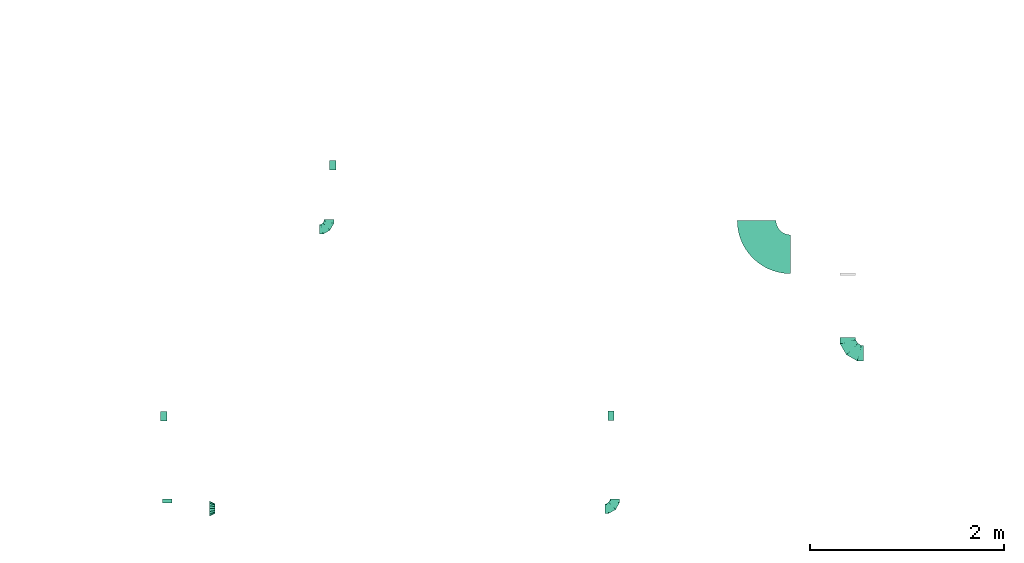
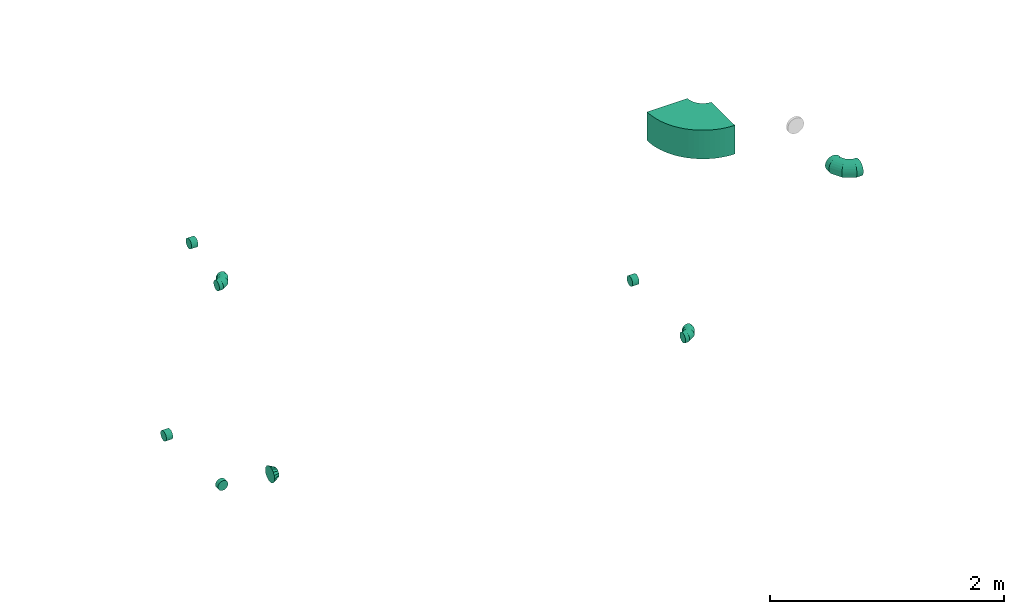
# One storey, part 14 of 32: 9 flow fittings.
"""IFC2X3 building model written with IfcOpenShell, lengths in millimetres."""

import ifcopenshell
import ifcopenshell.guid

model = None  # the IFC model being written
_history = None  # IfcOwnerHistory: only IFC2X3 demands one
_inside = {}  # id of a spatial element -> (the spatial element, [elements in it])
_under = {}  # id of a project, library or spatial element -> (it, [spatial elements below it])
_declared = {}  # id of a project -> (the project, [libraries it declares])
_typed = {}  # id of a type object -> (the type object, [elements of that type])
_made_of = {}  # id of a material, layer set ... -> (it, [elements and type objects made of it])


def new_model(schema):
    """Start an empty IFC model of exactly this schema.

    Asked for "IFC4X3", IfcOpenShell would pick the latest addendum, in which some entities
    have other attributes; the version numbers below select the first issue.
    IFC2X3 requires an IfcOwnerHistory on every rooted entity: one is made here for all.
    """
    global model, _history
    if schema == "IFC4X3":
        model = ifcopenshell.file(schema_version=(4, 3, 0, 0))
    else:
        model = ifcopenshell.file(schema=schema)
    _inside.clear()
    _under.clear()
    _declared.clear()
    _typed.clear()
    _made_of.clear()
    _history = None
    if model.schema == "IFC2X3":
        org = make("IfcOrganization", Name="unknown")
        user = make(
            "IfcPersonAndOrganization",
            ThePerson=make("IfcPerson", FamilyName="unknown"),
            TheOrganization=org,
        )
        app = make(
            "IfcApplication",
            ApplicationDeveloper=org,
            Version="unknown",
            ApplicationFullName="unknown",
            ApplicationIdentifier="unknown",
        )
        _history = make(
            "IfcOwnerHistory",
            OwningUser=user,
            OwningApplication=app,
            ChangeAction="ADDED",
            CreationDate=0,
        )
    return model


def make(cls, **values):
    """One entity of the class cls with the attributes given. An attribute that is None is left unset."""
    return model.create_entity(
        cls, **{name: value for name, value in values.items() if value is not None}
    )


def entity(cls, *values):
    """Any entity or typed value of the class cls, its attributes in the order of the schema. None: left unset."""
    e = model.create_entity(cls)
    for i, value in enumerate(values):
        if value is not None:
            e[i] = value
    return e


def rooted(cls, **values):
    """An entity with a GlobalId (a new one), such as an element, a storey or a relation."""
    return make(cls, GlobalId=ifcopenshell.guid.new(), OwnerHistory=_history, **values)


def si_unit(unit_type, name, prefix=None):
    """IfcSIUnit, for example si_unit("LENGTHUNIT", "METRE", prefix="MILLI")."""
    return make("IfcSIUnit", UnitType=unit_type, Prefix=prefix, Name=name)


def converted_unit(unit_type, name, factor, base, dimensions=None, offset=None):
    """IfcConversionBasedUnit, such as the inch: factor (a typed value) times the base unit."""
    return make(
        "IfcConversionBasedUnit"
        if offset is None
        else "IfcConversionBasedUnitWithOffset",
        ConversionOffset=offset,
        Dimensions=None
        if dimensions is None
        else entity("IfcDimensionalExponents", *dimensions),
        UnitType=unit_type,
        Name=name,
        ConversionFactor=make(
            "IfcMeasureWithUnit", ValueComponent=factor, UnitComponent=base
        ),
    )


def derived_unit(unit_type, elements):
    """IfcDerivedUnit: a product of units, each with its exponent."""
    return make(
        "IfcDerivedUnit",
        Elements=[
            make("IfcDerivedUnitElement", Unit=unit, Exponent=power)
            for unit, power in elements
        ],
        UnitType=unit_type,
    )


def assignment(units):
    """IfcUnitAssignment: the units of a project."""
    return None if units is None else make("IfcUnitAssignment", Units=units)


def point(xyz):
    """IfcCartesianPoint."""
    return None if xyz is None else make("IfcCartesianPoint", Coordinates=xyz)


def direction(xyz):
    """IfcDirection."""
    return None if xyz is None else make("IfcDirection", DirectionRatios=xyz)


def frame(location, z_axis=None, x_axis=None):
    """IfcAxis2Placement3D, a coordinate frame: its origin and axes. An axis left out is left unset."""
    return make(
        "IfcAxis2Placement3D",
        Location=point(location),
        Axis=direction(z_axis),
        RefDirection=direction(x_axis),
    )


def frame_2d(location, x_axis=None):
    """IfcAxis2Placement2D, a coordinate frame in the plane: its origin and x axis."""
    return make(
        "IfcAxis2Placement2D", Location=point(location), RefDirection=direction(x_axis)
    )


def origin():
    """The frame at (0, 0, 0) with its axes left unset."""
    return frame((0.0, 0.0, 0.0))


def place(relative_to, where):
    """IfcLocalPlacement: puts the frame where relative to a parent placement (None: the world)."""
    return make(
        "IfcLocalPlacement", PlacementRelTo=relative_to, RelativePlacement=where
    )


def context(
    kind, dimensions, precision=None, world=None, true_north=None, identifier=None
):
    """IfcGeometricRepresentationContext, for example the 3D "Model" context."""
    return make(
        "IfcGeometricRepresentationContext",
        ContextIdentifier=identifier,
        ContextType=kind,
        CoordinateSpaceDimension=dimensions,
        Precision=precision,
        WorldCoordinateSystem=world,
        TrueNorth=true_north,
    )


def subcontext(parent, identifier, kind, view, scale=None):
    """IfcGeometricRepresentationSubContext, for example "Body" below "Model"."""
    return make(
        "IfcGeometricRepresentationSubContext",
        ContextIdentifier=identifier,
        ContextType=kind,
        ParentContext=parent,
        TargetScale=scale,
        TargetView=view,
    )


def project(units=None, contexts=None):
    """IfcProject with its units and contexts."""
    return rooted(
        "IfcProject",
        Name="project",
        RepresentationContexts=contexts,
        UnitsInContext=assignment(units),
    )


def spatial(cls, under=None, at=None, **own):
    """A site, building, storey or space (cls), placed at a placement, below another one or the project."""
    s = rooted(cls, ObjectPlacement=at, **own)
    if under is not None:
        _under.setdefault(under.id(), (under, []))[1].append(s)
    return s


def polyline(points):
    """IfcPolyline through the points."""
    return make("IfcPolyline", Points=[point(p) for p in points])


def circle_curve(where, radius):
    """IfcCircle in the frame where."""
    return make("IfcCircle", Position=where, Radius=radius)


def parameter(value):
    """IfcParameterValue: where a trimmed curve begins or ends, as a parameter of its basis curve."""
    return model.create_entity("IfcParameterValue", value)


def trimmed(basis, trim1, trim2, sense, master):
    """IfcTrimmedCurve: the piece of a basis curve between two trims."""
    return make(
        "IfcTrimmedCurve",
        BasisCurve=basis,
        Trim1=trim1,
        Trim2=trim2,
        SenseAgreement=sense,
        MasterRepresentation=master,
    )


def segment(curve, same_sense, transition):
    """IfcCompositeCurveSegment."""
    return make(
        "IfcCompositeCurveSegment",
        Transition=transition,
        SameSense=same_sense,
        ParentCurve=curve,
    )


def composite_curve(segments, self_intersect=None):
    """IfcCompositeCurve: segments joined end to end."""
    return make("IfcCompositeCurve", Segments=segments, SelfIntersect=self_intersect)


def outline(outer, holes=None, kind="AREA"):
    """IfcArbitraryClosedProfileDef: a profile drawn as a closed curve; with holes, ...WithVoids."""
    if holes is None:
        return make("IfcArbitraryClosedProfileDef", ProfileType=kind, OuterCurve=outer)
    return make(
        "IfcArbitraryProfileDefWithVoids",
        ProfileType=kind,
        OuterCurve=outer,
        InnerCurves=holes,
    )


def extrude(swept, where, along, depth):
    """IfcExtrudedAreaSolid: the profile swept, set in the frame where, extruded along a direction by depth."""
    return make(
        "IfcExtrudedAreaSolid",
        SweptArea=swept,
        Position=where,
        ExtrudedDirection=direction(along),
        Depth=depth,
    )


def faces_of(points, faces, orient=None, outer=None):
    """IfcFace entities. A face is a list of loops; a loop is a list of indices into points, from 0.

    orient and outer hold one flag for each loop. By default every Orientation is true, the
    first loop of a face is its IfcFaceOuterBound and the others are IfcFaceBound.
    """
    made = []
    for i, loops in enumerate(faces):
        bounds = []
        for j, loop in enumerate(loops):
            is_outer = j == 0 if outer is None else outer[i][j]
            bounds.append(
                make(
                    "IfcFaceOuterBound" if is_outer else "IfcFaceBound",
                    Bound=make("IfcPolyLoop", Polygon=[points[k] for k in loop]),
                    Orientation=True if orient is None else orient[i][j],
                )
            )
        made.append(make("IfcFace", Bounds=bounds))
    return made


def faceted_brep(points, faces, orient=None, outer=None, voids=None):
    """IfcFacetedBrep: a solid bounded by flat faces; with voids (closed shells), ...WithVoids."""
    shared = [point(p) for p in points]
    hull = make("IfcClosedShell", CfsFaces=faces_of(shared, faces, orient, outer))
    if voids is None:
        return make("IfcFacetedBrep", Outer=hull)
    return make(
        "IfcFacetedBrepWithVoids",
        Outer=hull,
        Voids=[
            make(cls, CfsFaces=faces_of(shared, fs, o, b)) for cls, fs, o, b in voids
        ],
    )


def shape(context_of_items, identifier, shape_type, items):
    """IfcShapeRepresentation: the items that make up one representation, for example the "Body"."""
    return make(
        "IfcShapeRepresentation",
        ContextOfItems=context_of_items,
        RepresentationIdentifier=identifier,
        RepresentationType=shape_type,
        Items=items,
    )


def source(mapping_origin, context_of_items, identifier, shape_type, items):
    """IfcRepresentationMap: a shape defined once, which mapped items show again and again."""
    return make(
        "IfcRepresentationMap",
        MappingOrigin=mapping_origin,
        MappedRepresentation=shape(context_of_items, identifier, shape_type, items),
    )


def transform(
    local_origin,
    x_axis=None,
    y_axis=None,
    z_axis=None,
    scale=None,
    scale2=None,
    scale3=None,
    uniform=True,
):
    """IfcCartesianTransformationOperator3D, or its non-uniform kind. x_axis, y_axis, z_axis: its Axis1, 2, 3."""
    if uniform:
        return make(
            "IfcCartesianTransformationOperator3D",
            Axis1=direction(x_axis),
            Axis2=direction(y_axis),
            LocalOrigin=point(local_origin),
            Scale=scale,
            Axis3=direction(z_axis),
        )
    return make(
        "IfcCartesianTransformationOperator3DnonUniform",
        Axis1=direction(x_axis),
        Axis2=direction(y_axis),
        LocalOrigin=point(local_origin),
        Scale=scale,
        Axis3=direction(z_axis),
        Scale2=scale2,
        Scale3=scale3,
    )


def mapped(mapping_source, mapping_target):
    """IfcMappedItem: shows the shape of a source again, moved by a transform."""
    return make(
        "IfcMappedItem", MappingSource=mapping_source, MappingTarget=mapping_target
    )


def material(Name=None, Category=None):
    """IfcMaterial."""
    return make("IfcMaterial", Name=Name, Category=Category)


def made_of(thing, what):
    """Note that an element or type object is made of a material, layer set ...; save() writes the relation."""
    if what is not None:
        _made_of.setdefault(what.id(), (what, []))[1].append(thing)
    return thing


def type_object(cls, material=None, **own):
    """A type object (cls), such as IfcWallType, which elements share."""
    return made_of(rooted(cls, **own), material)


def type_shapes(of_type, sources):
    """Give a type object the sources (RepresentationMaps) that its elements show as mapped items."""
    of_type.RepresentationMaps = sources


def element(
    cls,
    number,
    at=None,
    inside=None,
    cuts=None,
    type_object=None,
    material=None,
    context=None,
    identifier="Body",
    shape_type=None,
    held_by="IfcProductDefinitionShape",
    body=None,
    shapes=None,
    **own,
):
    """One element of the class cls, such as IfcWall. Its Tag is "e" and its number.

    at: its placement. inside: the storey or other place that contains it. cuts: it is an
    opening in that element (IfcRelVoidsElement). A single representation is given by context,
    identifier, shape_type and body (its items); several are given by shapes. held_by: the class
    of the entity that holds the representations. save() writes the other relations.
    """
    e = rooted(cls, Tag="e%d" % number, ObjectPlacement=at, **own)
    if body is not None:
        shapes = [shape(context, identifier, shape_type, body)]
    if shapes is not None:
        e.Representation = make(held_by, Representations=shapes)
    if inside is not None:
        _inside.setdefault(inside.id(), (inside, []))[1].append(e)
    if cuts is not None:
        rooted(
            "IfcRelVoidsElement", RelatingBuildingElement=cuts, RelatedOpeningElement=e
        )
    if type_object is not None:
        _typed.setdefault(type_object.id(), (type_object, []))[1].append(e)
    return made_of(e, material)


def aggregate(whole, parts):
    """IfcRelAggregates: a whole, such as a stair, and the parts it consists of."""
    return rooted("IfcRelAggregates", RelatingObject=whole, RelatedObjects=parts)


def save(model, path):
    """Write the relations noted so far, then the file.

    IfcRelAggregates (storeys below a building ...), IfcRelContainedInSpatialStructure (elements
    in a storey), IfcRelDefinesByType, IfcRelAssociatesMaterial and IfcRelDeclares: one each for
    every whole, place, type object, material and project.
    """
    for whole, parts in _under.values():
        aggregate(whole, parts)
    for where, things in _inside.values():
        rooted(
            "IfcRelContainedInSpatialStructure",
            RelatedElements=things,
            RelatingStructure=where,
        )
    for kind, things in _typed.values():
        rooted("IfcRelDefinesByType", RelatedObjects=things, RelatingType=kind)
    for what, things in _made_of.values():
        rooted("IfcRelAssociatesMaterial", RelatedObjects=things, RelatingMaterial=what)
    for by, libraries in _declared.values():
        rooted("IfcRelDeclares", RelatingContext=by, RelatedDefinitions=libraries)
    model.write(path)


model = new_model("IFC2X3")

# Units and contexts
model_context = context("Model", 3, precision=0.01, world=origin(), true_north=direction((6.12303176911189e-17, 1.0)))
body_context = subcontext(model_context, "Body", "Model", "MODEL_VIEW")
ifc_project = project(units=[si_unit("LENGTHUNIT", "METRE", prefix="MILLI"), si_unit("AREAUNIT", "SQUARE_METRE"), si_unit("VOLUMEUNIT", "CUBIC_METRE"), converted_unit("PLANEANGLEUNIT", "DEGREE", entity("IfcRatioMeasure", 0.0174532925199433), si_unit("PLANEANGLEUNIT", "RADIAN"), dimensions=[0, 0, 0, 0, 0, 0, 0]), si_unit("MASSUNIT", "GRAM", prefix="KILO"), derived_unit("MASSDENSITYUNIT", [(si_unit("MASSUNIT", "GRAM", prefix="KILO"), 1), (si_unit("LENGTHUNIT", "METRE"), -3)]), derived_unit("MOMENTOFINERTIAUNIT", [(si_unit("LENGTHUNIT", "METRE"), 4)]), si_unit("TIMEUNIT", "SECOND"), si_unit("FREQUENCYUNIT", "HERTZ"), si_unit("THERMODYNAMICTEMPERATUREUNIT", "DEGREE_CELSIUS"), derived_unit("THERMALTRANSMITTANCEUNIT", [(si_unit("MASSUNIT", "GRAM", prefix="KILO"), 1), (si_unit("THERMODYNAMICTEMPERATUREUNIT", "KELVIN"), -1), (si_unit("TIMEUNIT", "SECOND"), -3)]), derived_unit("VOLUMETRICFLOWRATEUNIT", [(si_unit("LENGTHUNIT", "METRE"), 3), (si_unit("TIMEUNIT", "SECOND"), -1)]), derived_unit("MASSFLOWRATEUNIT", [(si_unit("MASSUNIT", "GRAM", prefix="KILO"), 1), (si_unit("TIMEUNIT", "SECOND"), -1)]), derived_unit("ROTATIONALFREQUENCYUNIT", [(si_unit("TIMEUNIT", "SECOND"), -1)]), si_unit("ELECTRICCURRENTUNIT", "AMPERE"), si_unit("ELECTRICVOLTAGEUNIT", "VOLT"), si_unit("POWERUNIT", "WATT"), si_unit("FORCEUNIT", "NEWTON", prefix="KILO"), si_unit("ILLUMINANCEUNIT", "LUX"), si_unit("LUMINOUSFLUXUNIT", "LUMEN"), si_unit("LUMINOUSINTENSITYUNIT", "CANDELA"), derived_unit("USERDEFINED", [(si_unit("MASSUNIT", "GRAM", prefix="KILO"), -1), (si_unit("LENGTHUNIT", "METRE"), -2), (si_unit("TIMEUNIT", "SECOND"), 3), (si_unit("LUMINOUSFLUXUNIT", "LUMEN"), 1)]), derived_unit("LINEARVELOCITYUNIT", [(si_unit("LENGTHUNIT", "METRE"), 1), (si_unit("TIMEUNIT", "SECOND"), -1)]), si_unit("PRESSUREUNIT", "PASCAL"), derived_unit("USERDEFINED", [(si_unit("LENGTHUNIT", "METRE"), -2), (si_unit("MASSUNIT", "GRAM", prefix="KILO"), 1), (si_unit("TIMEUNIT", "SECOND"), -2)]), derived_unit("LINEARFORCEUNIT", [(si_unit("MASSUNIT", "GRAM", prefix="KILO"), 1), (si_unit("LENGTHUNIT", "METRE"), 1), (si_unit("TIMEUNIT", "SECOND"), -2), (si_unit("LENGTHUNIT", "METRE"), -1)]), derived_unit("PLANARFORCEUNIT", [(si_unit("MASSUNIT", "GRAM", prefix="KILO"), 1), (si_unit("LENGTHUNIT", "METRE"), 1), (si_unit("TIMEUNIT", "SECOND"), -2), (si_unit("LENGTHUNIT", "METRE"), -2)])], contexts=[model_context])

# Site, building, storey
site_placement = place(None, origin())
site = spatial("IfcSite", under=ifc_project, at=site_placement, CompositionType="ELEMENT")
building_placement = place(site_placement, origin())
building = spatial("IfcBuilding", under=site, at=building_placement, CompositionType="ELEMENT")
storey_placement = place(building_placement, frame((0.0, 0.0, 8100.0)))
storey = spatial("IfcBuildingStorey", under=building, at=storey_placement, CompositionType="ELEMENT", Elevation=8100.0)

# Flow fittings
ifc_material = material()
duct_fitting_type_1 = type_object("IfcDuctFittingType", PredefinedType="NOTDEFINED", material=ifc_material)
shared_shape_1 = source(origin(), body_context, "Body", "Brep", [
    faceted_brep([(-160.0, 0.0, -80.0), (-160.0, -20.71, -77.27), (-160.0, -40.0, -69.28), (-160.0, -56.57, -56.57), (-160.0, -69.28, -40.0), (-160.0, -77.27, -20.71), (-160.0, -80.0, 0.0), (-160.0, -77.27, 20.71), (-160.0, -69.28, 40.0), (-160.0, -56.57, 56.57), (-160.0, -40.0, 69.28), (-160.0, -20.71, 77.27), (-160.0, 0.0, 80.0), (-160.0, 20.71, 77.27), (-160.0, 40.0, 69.28), (-160.0, 56.57, 56.57), (-160.0, 69.28, 40.0), (-160.0, 77.27, 20.71), (-160.0, 80.0, 0.0), (-160.0, 77.27, -20.71), (-160.0, 69.28, -40.0), (-160.0, 56.57, -56.57), (-160.0, 40.0, -69.28), (-160.0, 20.71, -77.27), (-122.68, 20.71, 77.27), (-127.85, 40.0, 69.28), (-117.13, 0.0, 80.0), (-132.29, 56.57, 56.57), (-137.83, 77.27, 20.71), (-138.56, 80.0, 0.0), (-135.69, 69.28, 40.0), (-135.69, 69.28, -40.0), (-132.29, 56.57, -56.57), (-137.83, 77.27, -20.71), (-122.68, 20.71, -77.27), (-117.13, 0.0, -80.0), (-127.85, 40.0, -69.28), (-111.58, -20.71, -77.27), (-106.41, -40.0, -69.28), (-101.97, -56.57, -56.57), (-98.56, -69.28, -40.0), (-96.42, -77.27, -20.71), (-95.69, -80.0, 0.0), (-96.42, -77.27, 20.71), (-98.56, -69.28, 40.0), (-101.97, -56.57, 56.57), (-106.41, -40.0, 69.28), (-111.58, -20.71, 77.27), (-58.03, 58.03, 77.27), (-72.15, 72.15, 69.28), (-42.87, 42.87, 80.0), (-84.28, 84.28, 56.57), (-93.59, 93.59, 40.0), (-99.44, 99.44, 20.71), (-101.44, 101.44, 0.0), (-99.44, 99.44, -20.71), (-93.59, 93.59, -40.0), (-84.28, 84.28, -56.57), (-58.03, 58.03, -77.27), (-42.87, 42.87, -80.0), (-72.15, 72.15, -69.28), (-27.71, 27.71, -77.27), (-13.59, 13.59, -69.28), (-1.46, 1.46, -56.57), (7.85, -7.85, -40.0), (13.7, -13.7, -20.71), (15.69, -15.69, 0.0), (13.7, -13.7, 20.71), (7.85, -7.85, 40.0), (-1.46, 1.46, 56.57), (-13.59, 13.59, 69.28), (-27.71, 27.71, 77.27), (-20.71, 122.68, 77.27), (-40.0, 127.85, 69.28), (0.0, 117.13, 80.0), (-56.57, 132.29, 56.57), (-69.28, 135.69, 40.0), (-77.27, 137.83, 20.71), (-80.0, 138.56, 0.0), (-77.27, 137.83, -20.71), (-69.28, 135.69, -40.0), (-56.57, 132.29, -56.57), (-20.71, 122.68, -77.27), (0.0, 117.13, -80.0), (-40.0, 127.85, -69.28), (20.71, 111.58, -77.27), (40.0, 106.41, -69.28), (56.57, 101.97, -56.57), (69.28, 98.56, -40.0), (77.27, 96.42, -20.71), (80.0, 95.69, 0.0), (77.27, 96.42, 20.71), (69.28, 98.56, 40.0), (56.57, 101.97, 56.57), (40.0, 106.41, 69.28), (20.71, 111.58, 77.27), (-20.71, 160.0, -77.27), (-40.0, 160.0, -69.28), (-56.57, 160.0, -56.57), (-69.28, 160.0, -40.0), (-77.27, 160.0, -20.71), (-80.0, 160.0, 0.0), (-77.27, 160.0, 20.71), (-69.28, 160.0, 40.0), (-56.57, 160.0, 56.57), (-40.0, 160.0, 69.28), (-20.71, 160.0, 77.27), (0.0, 160.0, 80.0), (20.71, 160.0, 77.27), (40.0, 160.0, 69.28), (56.57, 160.0, 56.57), (69.28, 160.0, 40.0), (77.27, 160.0, 20.71), (80.0, 160.0, 0.0), (77.27, 160.0, -20.71), (69.28, 160.0, -40.0), (56.57, 160.0, -56.57), (40.0, 160.0, -69.28), (20.71, 160.0, -77.27), (0.0, 160.0, -80.0)], [[[0, 1, 2, 3, 4, 5, 6, 7, 8, 9, 10, 11, 12, 13, 14, 15, 16, 17, 18, 19, 20, 21, 22, 23]], [[24, 25, 14, 13]], [[26, 24, 13, 12]], [[14, 25, 27, 15]], [[28, 29, 18, 17]], [[30, 28, 17, 16]], [[15, 27, 30, 16]], [[20, 31, 32, 21]], [[33, 31, 20, 19]], [[18, 29, 33, 19]], [[34, 35, 0, 23]], [[36, 34, 23, 22]], [[32, 36, 22, 21]], [[1, 0, 35, 37]], [[2, 1, 37, 38]], [[3, 2, 38, 39]], [[5, 4, 40, 41]], [[6, 5, 41, 42]], [[39, 40, 4, 3]], [[6, 42, 43, 7]], [[7, 43, 44, 8]], [[8, 44, 45, 9]], [[9, 45, 46, 10]], [[10, 46, 47, 11]], [[26, 12, 11, 47]], [[48, 49, 25, 24]], [[50, 48, 24, 26]], [[27, 25, 49, 51]], [[52, 53, 28, 30]], [[51, 52, 30, 27]], [[29, 28, 53, 54]], [[55, 56, 31, 33]], [[54, 55, 33, 29]], [[32, 31, 56, 57]], [[58, 59, 35, 34]], [[60, 58, 34, 36]], [[57, 60, 36, 32]], [[37, 35, 59, 61]], [[38, 37, 61, 62]], [[39, 38, 62, 63]], [[41, 40, 64, 65]], [[42, 41, 65, 66]], [[63, 64, 40, 39]], [[43, 42, 66, 67]], [[44, 43, 67, 68]], [[68, 69, 45, 44]], [[46, 45, 69, 70]], [[47, 46, 70, 71]], [[26, 47, 71, 50]], [[72, 73, 49, 48]], [[74, 72, 48, 50]], [[51, 49, 73, 75]], [[76, 77, 53, 52]], [[75, 76, 52, 51]], [[54, 53, 77, 78]], [[79, 80, 56, 55]], [[78, 79, 55, 54]], [[57, 56, 80, 81]], [[82, 83, 59, 58]], [[84, 82, 58, 60]], [[81, 84, 60, 57]], [[61, 59, 83, 85]], [[62, 61, 85, 86]], [[63, 62, 86, 87]], [[65, 64, 88, 89]], [[66, 65, 89, 90]], [[87, 88, 64, 63]], [[67, 66, 90, 91]], [[68, 67, 91, 92]], [[92, 93, 69, 68]], [[70, 69, 93, 94]], [[71, 70, 94, 95]], [[50, 71, 95, 74]], [[96, 97, 98, 99, 100, 101, 102, 103, 104, 105, 106, 107, 108, 109, 110, 111, 112, 113, 114, 115, 116, 117, 118, 119]], [[72, 74, 107, 106]], [[73, 72, 106, 105]], [[75, 73, 105, 104]], [[77, 76, 103, 102]], [[78, 77, 102, 101]], [[75, 104, 103, 76]], [[78, 101, 100, 79]], [[79, 100, 99, 80]], [[80, 99, 98, 81]], [[84, 97, 96, 82]], [[82, 96, 119, 83]], [[84, 81, 98, 97]], [[118, 117, 86, 85]], [[119, 118, 85, 83]], [[116, 87, 86, 117]], [[88, 115, 114, 89]], [[89, 114, 113, 90]], [[115, 88, 87, 116]], [[112, 111, 92, 91]], [[113, 112, 91, 90]], [[111, 110, 93, 92]], [[95, 94, 109, 108]], [[74, 95, 108, 107]], [[110, 109, 94, 93]]]),
])
type_shapes(duct_fitting_type_1, [shared_shape_1])
flow_fitting_1_placement = place(storey_placement, frame((40938.46, 2102.88, 3250.0), z_axis=(0.0, 0.0, 1.0), x_axis=(0.0, -1.0, 0.0)))
element("IfcFlowFitting", 1, at=flow_fitting_1_placement, inside=storey, type_object=duct_fitting_type_1, material=ifc_material, context=body_context, shape_type="MappedRepresentation", body=[
    mapped(shared_shape_1, transform((0.0, 0.0, 0.0), scale=1.0)),
])
duct_fitting_type_2 = type_object("IfcDuctFittingType", PredefinedType="NOTDEFINED", material=ifc_material)
shared_shape_2 = source(origin(), body_context, "Body", "Brep", [
    faceted_brep([(-100.0, 0.0, -50.0), (-100.0, -12.94, -48.3), (-100.0, -25.0, -43.3), (-100.0, -35.36, -35.36), (-100.0, -43.3, -25.0), (-100.0, -48.3, -12.94), (-100.0, -50.0, 0.0), (-100.0, -48.3, 12.94), (-100.0, -43.3, 25.0), (-100.0, -35.36, 35.36), (-100.0, -25.0, 43.3), (-100.0, -12.94, 48.3), (-100.0, 0.0, 50.0), (-100.0, 12.94, 48.3), (-100.0, 25.0, 43.3), (-100.0, 35.36, 35.36), (-100.0, 43.3, 25.0), (-100.0, 48.3, 12.94), (-100.0, 50.0, 0.0), (-100.0, 48.3, -12.94), (-100.0, 43.3, -25.0), (-100.0, 35.36, -35.36), (-100.0, 25.0, -43.3), (-100.0, 12.94, -48.3), (-76.67, 12.94, 48.3), (-79.9, 25.0, 43.3), (-73.21, 0.0, 50.0), (-82.68, 35.36, 35.36), (-86.15, 48.3, 12.94), (-86.6, 50.0, 0.0), (-84.81, 43.3, 25.0), (-84.81, 43.3, -25.0), (-82.68, 35.36, -35.36), (-86.15, 48.3, -12.94), (-76.67, 12.94, -48.3), (-73.21, 0.0, -50.0), (-79.9, 25.0, -43.3), (-69.74, -12.94, -48.3), (-66.51, -25.0, -43.3), (-63.73, -35.36, -35.36), (-61.6, -43.3, -25.0), (-60.26, -48.3, -12.94), (-59.81, -50.0, 0.0), (-60.26, -48.3, 12.94), (-61.6, -43.3, 25.0), (-63.73, -35.36, 35.36), (-66.51, -25.0, 43.3), (-69.74, -12.94, 48.3), (-36.27, 36.27, 48.3), (-45.1, 45.1, 43.3), (-26.79, 26.79, 50.0), (-52.68, 52.68, 35.36), (-58.49, 58.49, 25.0), (-62.15, 62.15, 12.94), (-63.4, 63.4, 0.0), (-62.15, 62.15, -12.94), (-58.49, 58.49, -25.0), (-52.68, 52.68, -35.36), (-36.27, 36.27, -48.3), (-26.79, 26.79, -50.0), (-45.1, 45.1, -43.3), (-17.32, 17.32, -48.3), (-8.49, 8.49, -43.3), (-0.91, 0.91, -35.36), (4.9, -4.9, -25.0), (8.56, -8.56, -12.94), (9.81, -9.81, 0.0), (8.56, -8.56, 12.94), (4.9, -4.9, 25.0), (-0.91, 0.91, 35.36), (-8.49, 8.49, 43.3), (-17.32, 17.32, 48.3), (-12.94, 76.67, 48.3), (-25.0, 79.9, 43.3), (0.0, 73.21, 50.0), (-35.36, 82.68, 35.36), (-43.3, 84.81, 25.0), (-48.3, 86.15, 12.94), (-50.0, 86.6, 0.0), (-48.3, 86.15, -12.94), (-43.3, 84.81, -25.0), (-35.36, 82.68, -35.36), (-12.94, 76.67, -48.3), (0.0, 73.21, -50.0), (-25.0, 79.9, -43.3), (12.94, 69.74, -48.3), (25.0, 66.51, -43.3), (35.36, 63.73, -35.36), (43.3, 61.6, -25.0), (48.3, 60.26, -12.94), (50.0, 59.81, 0.0), (48.3, 60.26, 12.94), (43.3, 61.6, 25.0), (35.36, 63.73, 35.36), (25.0, 66.51, 43.3), (12.94, 69.74, 48.3), (-12.94, 100.0, -48.3), (-25.0, 100.0, -43.3), (-35.36, 100.0, -35.36), (-43.3, 100.0, -25.0), (-48.3, 100.0, -12.94), (-50.0, 100.0, 0.0), (-48.3, 100.0, 12.94), (-43.3, 100.0, 25.0), (-35.36, 100.0, 35.36), (-25.0, 100.0, 43.3), (-12.94, 100.0, 48.3), (0.0, 100.0, 50.0), (12.94, 100.0, 48.3), (25.0, 100.0, 43.3), (35.36, 100.0, 35.36), (43.3, 100.0, 25.0), (48.3, 100.0, 12.94), (50.0, 100.0, 0.0), (48.3, 100.0, -12.94), (43.3, 100.0, -25.0), (35.36, 100.0, -35.36), (25.0, 100.0, -43.3), (12.94, 100.0, -48.3), (0.0, 100.0, -50.0)], [[[0, 1, 2, 3, 4, 5, 6, 7, 8, 9, 10, 11, 12, 13, 14, 15, 16, 17, 18, 19, 20, 21, 22, 23]], [[24, 25, 14, 13]], [[26, 24, 13, 12]], [[14, 25, 27, 15]], [[28, 29, 18, 17]], [[30, 28, 17, 16]], [[15, 27, 30, 16]], [[20, 31, 32, 21]], [[33, 31, 20, 19]], [[18, 29, 33, 19]], [[34, 35, 0, 23]], [[36, 34, 23, 22]], [[32, 36, 22, 21]], [[2, 1, 37, 38]], [[3, 2, 38, 39]], [[0, 35, 37, 1]], [[5, 4, 40, 41]], [[6, 5, 41, 42]], [[3, 39, 40, 4]], [[6, 42, 43, 7]], [[7, 43, 44, 8]], [[8, 44, 45, 9]], [[10, 46, 47, 11]], [[11, 47, 26, 12]], [[10, 9, 45, 46]], [[48, 49, 25, 24]], [[50, 48, 24, 26]], [[27, 25, 49, 51]], [[52, 53, 28, 30]], [[51, 52, 30, 27]], [[29, 28, 53, 54]], [[55, 56, 31, 33]], [[54, 55, 33, 29]], [[57, 32, 31, 56]], [[58, 59, 35, 34]], [[60, 58, 34, 36]], [[57, 60, 36, 32]], [[37, 35, 59, 61]], [[38, 37, 61, 62]], [[39, 38, 62, 63]], [[41, 40, 64, 65]], [[42, 41, 65, 66]], [[63, 64, 40, 39]], [[43, 42, 66, 67]], [[44, 43, 67, 68]], [[68, 69, 45, 44]], [[46, 45, 69, 70]], [[47, 46, 70, 71]], [[26, 47, 71, 50]], [[72, 73, 49, 48]], [[74, 72, 48, 50]], [[51, 49, 73, 75]], [[76, 77, 53, 52]], [[75, 76, 52, 51]], [[54, 53, 77, 78]], [[79, 80, 56, 55]], [[78, 79, 55, 54]], [[81, 57, 56, 80]], [[82, 83, 59, 58]], [[84, 82, 58, 60]], [[81, 84, 60, 57]], [[61, 59, 83, 85]], [[62, 61, 85, 86]], [[63, 62, 86, 87]], [[65, 64, 88, 89]], [[66, 65, 89, 90]], [[87, 88, 64, 63]], [[67, 66, 90, 91]], [[68, 67, 91, 92]], [[92, 93, 69, 68]], [[70, 69, 93, 94]], [[71, 70, 94, 95]], [[50, 71, 95, 74]], [[96, 97, 98, 99, 100, 101, 102, 103, 104, 105, 106, 107, 108, 109, 110, 111, 112, 113, 114, 115, 116, 117, 118, 119]], [[72, 74, 107, 106]], [[73, 72, 106, 105]], [[75, 73, 105, 104]], [[77, 76, 103, 102]], [[78, 77, 102, 101]], [[75, 104, 103, 76]], [[78, 101, 100, 79]], [[79, 100, 99, 80]], [[80, 99, 98, 81]], [[96, 119, 83, 82]], [[97, 96, 82, 84]], [[84, 81, 98, 97]], [[83, 119, 118, 85]], [[85, 118, 117, 86]], [[86, 117, 116, 87]], [[88, 115, 114, 89]], [[89, 114, 113, 90]], [[87, 116, 115, 88]], [[91, 90, 113, 112]], [[92, 91, 112, 111]], [[93, 92, 111, 110]], [[95, 94, 109, 108]], [[74, 95, 108, 107]], [[110, 109, 94, 93]]]),
])
type_shapes(duct_fitting_type_2, [shared_shape_2])
for number, where in (
    (2, (35587.3, 3380.54, 3200.0)),
    (3, (38532.77, 500.02, 3370.0)),
):
    element("IfcFlowFitting", number, at=place(storey_placement, frame(where)), inside=storey, type_object=duct_fitting_type_2, material=ifc_material, context=body_context, shape_type="MappedRepresentation", body=[
        mapped(shared_shape_2, transform((0.0, 0.0, 0.0), scale=1.0)),
    ])
duct_fitting_type_3 = type_object("IfcDuctFittingType", PredefinedType="NOTDEFINED", material=ifc_material)
shared_shape_3 = source(origin(), body_context, "Body", "Brep", [
    faceted_brep([(60.0, -46.19, 19.13), (60.0, -48.1, 9.57), (60.0, -50.0, 0.0), (60.0, -48.1, -9.57), (60.0, -46.19, -19.13), (60.0, -40.77, -27.24), (60.0, -35.36, -35.36), (60.0, -27.24, -40.77), (60.0, -19.13, -46.19), (60.0, -9.57, -48.1), (60.0, 0.0, -50.0), (60.0, 9.57, -48.1), (60.0, 19.13, -46.19), (60.0, 27.24, -40.77), (60.0, 35.36, -35.36), (60.0, 40.77, -27.24), (60.0, 46.19, -19.13), (60.0, 48.1, -9.57), (60.0, 50.0, 0.0), (60.0, 48.1, 9.57), (60.0, 46.19, 19.13), (60.0, 40.77, 27.24), (60.0, 35.36, 35.36), (60.0, 27.24, 40.77), (60.0, 19.13, 46.19), (60.0, 9.57, 48.1), (60.0, 0.0, 50.0), (60.0, -9.57, 48.1), (60.0, -19.13, 46.19), (60.0, -27.24, 40.77), (60.0, -35.36, 35.36), (60.0, -40.77, 27.24), (0.0, -80.0, 0.0), (0.0, -77.16, 14.27), (0.0, -73.91, 30.61), (0.0, -65.24, 43.59), (0.0, -56.57, 56.57), (0.0, -43.59, 65.24), (0.0, -30.61, 73.91), (0.0, -15.31, 76.96), (0.0, 0.0, 80.0), (0.0, 14.27, 77.16), (0.0, 30.61, 73.91), (0.0, 43.59, 65.24), (0.0, 56.57, 56.57), (0.0, 65.24, 43.59), (0.0, 73.91, 30.61), (0.0, 76.96, 15.31), (0.0, 80.0, 0.0), (0.0, 77.16, -14.27), (0.0, 73.91, -30.61), (0.0, 65.24, -43.59), (0.0, 56.57, -56.57), (0.0, 43.59, -65.24), (0.0, 30.61, -73.91), (0.0, 15.31, -76.96), (0.0, 0.0, -80.0), (0.0, -14.27, -77.16), (0.0, -30.61, -73.91), (0.0, -43.59, -65.24), (0.0, -56.57, -56.57), (0.0, -65.24, -43.59), (0.0, -73.91, -30.61), (0.0, -76.96, -15.31)], [[[0, 1, 2, 3, 4, 5, 6, 7, 8, 9, 10, 11, 12, 13, 14, 15, 16, 17, 18, 19, 20, 21, 22, 23, 24, 25, 26, 27, 28, 29, 30, 31]], [[32, 33, 34, 35, 36, 37, 38, 39, 40, 41, 42, 43, 44, 45, 46, 47, 48, 49, 50, 51, 52, 53, 54, 55, 56, 57, 58, 59, 60, 61, 62, 63]], [[42, 41, 40, 26, 25, 24]], [[43, 42, 24, 23, 22, 44]], [[20, 46, 45, 44, 22, 21]], [[18, 48, 47, 46, 20, 19]], [[34, 33, 32, 2, 1, 0]], [[35, 34, 0, 31, 30, 36]], [[28, 38, 37, 36, 30, 29]], [[26, 40, 39, 38, 28, 27]], [[58, 57, 56, 10, 9, 8]], [[59, 58, 8, 7, 6, 60]], [[4, 62, 61, 60, 6, 5]], [[2, 32, 63, 62, 4, 3]], [[50, 49, 48, 18, 17, 16]], [[51, 50, 16, 15, 14, 52]], [[12, 54, 53, 52, 14, 13]], [[10, 56, 55, 54, 12, 11]]]),
])
type_shapes(duct_fitting_type_3, [shared_shape_3])
flow_fitting_2_placement = place(storey_placement, frame((34352.77, 500.02, 3370.0)))
element("IfcFlowFitting", 4, at=flow_fitting_2_placement, inside=storey, type_object=duct_fitting_type_3, material=ifc_material, context=body_context, shape_type="MappedRepresentation", body=[
    mapped(shared_shape_3, transform((0.0, 0.0, 0.0), scale=1.0)),
])
duct_fitting_type_4 = type_object("IfcDuctFittingType", PredefinedType="NOTDEFINED", material=ifc_material)
shared_shape_4 = source(origin(), body_context, "Body", "Brep", [
    faceted_brep([(20.0, 12.94, -48.3), (20.0, 25.0, -43.3), (20.0, 35.36, -35.36), (20.0, 43.3, -25.0), (20.0, 48.3, -12.94), (20.0, 50.0, 0.0), (20.0, 48.3, 12.94), (20.0, 43.3, 25.0), (20.0, 35.36, 35.36), (20.0, 25.0, 43.3), (20.0, 12.94, 48.3), (20.0, 0.0, 50.0), (20.0, -12.94, 48.3), (20.0, -25.0, 43.3), (20.0, -35.36, 35.36), (20.0, -43.3, 25.0), (20.0, -48.3, 12.94), (20.0, -50.0, 0.0), (20.0, -48.3, -12.94), (20.0, -43.3, -25.0), (20.0, -35.36, -35.36), (20.0, -25.0, -43.3), (20.0, -12.94, -48.3), (20.0, 0.0, -50.0), (0.0, 0.0, 50.0), (0.0, 12.94, 48.3), (-43.9, 12.94, 48.3), (-43.9, 0.0, 50.0), (0.0, 25.0, 43.3), (-43.9, 25.0, 43.3), (0.0, 35.36, 35.36), (-43.9, 35.36, 35.36), (0.0, 43.3, 25.0), (0.0, 48.3, 12.94), (-43.9, 48.3, 12.94), (-43.9, 43.3, 25.0), (0.0, 50.0, 0.0), (-43.9, 50.0, 0.0), (0.0, 48.3, -12.94), (-43.9, 48.3, -12.94), (0.0, 43.3, -25.0), (-43.9, 43.3, -25.0), (0.0, 35.36, -35.36), (-43.9, 35.36, -35.36), (0.0, 25.0, -43.3), (0.0, 12.94, -48.3), (-43.9, 12.94, -48.3), (-43.9, 25.0, -43.3), (0.0, 0.0, -50.0), (-43.9, 0.0, -50.0), (0.0, -12.94, -48.3), (-43.9, -12.94, -48.3), (0.0, -25.0, -43.3), (-43.9, -25.0, -43.3), (0.0, -35.36, -35.36), (-43.9, -35.36, -35.36), (0.0, -43.3, -25.0), (0.0, -48.3, -12.94), (-43.9, -48.3, -12.94), (-43.9, -43.3, -25.0), (0.0, -50.0, 0.0), (-43.9, -50.0, 0.0), (0.0, -48.3, 12.94), (-43.9, -48.3, 12.94), (0.0, -43.3, 25.0), (-43.9, -43.3, 25.0), (0.0, -35.36, 35.36), (-43.9, -35.36, 35.36), (0.0, -25.0, 43.3), (0.0, -12.94, 48.3), (-43.9, -12.94, 48.3), (-43.9, -25.0, 43.3)], [[[0, 1, 2, 3, 4, 5, 6, 7, 8, 9, 10, 11, 12, 13, 14, 15, 16, 17, 18, 19, 20, 21, 22, 23]], [[24, 11, 10, 25, 26, 27]], [[25, 10, 9, 28, 29, 26]], [[28, 9, 8, 30, 31, 29]], [[32, 7, 6, 33, 34, 35]], [[33, 6, 5, 36, 37, 34]], [[30, 8, 7, 32, 35, 31]], [[36, 5, 4, 38, 39, 37]], [[38, 4, 3, 40, 41, 39]], [[40, 3, 2, 42, 43, 41]], [[44, 1, 0, 45, 46, 47]], [[45, 0, 23, 48, 49, 46]], [[42, 2, 1, 44, 47, 43]], [[48, 23, 22, 50, 51, 49]], [[50, 22, 21, 52, 53, 51]], [[52, 21, 20, 54, 55, 53]], [[56, 19, 18, 57, 58, 59]], [[57, 18, 17, 60, 61, 58]], [[54, 20, 19, 56, 59, 55]], [[60, 17, 16, 62, 63, 61]], [[62, 16, 15, 64, 65, 63]], [[64, 15, 14, 66, 67, 65]], [[68, 13, 12, 69, 70, 71]], [[69, 12, 11, 24, 27, 70]], [[66, 14, 13, 68, 71, 67]], [[49, 51, 53, 55, 59, 58, 61, 63, 65, 67, 71, 70, 27, 26, 29, 31, 35, 34, 37, 39, 41, 43, 47, 46]]]),
])
type_shapes(duct_fitting_type_4, [shared_shape_4])
flow_fitting_3_placement = place(storey_placement, frame((35637.3, 4040.54, 3200.0), z_axis=(0.0, 0.0, -1.0), x_axis=(1.0, 0.0, 0.0)))
element("IfcFlowFitting", 5, at=flow_fitting_3_placement, inside=storey, type_object=duct_fitting_type_4, material=ifc_material, context=body_context, shape_type="MappedRepresentation", body=[
    mapped(shared_shape_4, transform((0.0, 0.0, 0.0), scale=1.0)),
])
duct_fitting_type_5 = type_object("IfcDuctFittingType", PredefinedType="NOTDEFINED", material=ifc_material)
shared_shape_5 = source(origin(), body_context, "Body", "Brep", [
    faceted_brep([(20.0, 0.0, -50.0), (20.0, 12.94, -48.3), (20.0, 25.0, -43.3), (20.0, 35.36, -35.36), (20.0, 43.3, -25.0), (20.0, 48.3, -12.94), (20.0, 50.0, 0.0), (20.0, 48.3, 12.94), (20.0, 43.3, 25.0), (20.0, 35.36, 35.36), (20.0, 25.0, 43.3), (20.0, 12.94, 48.3), (20.0, 0.0, 50.0), (20.0, -12.94, 48.3), (20.0, -25.0, 43.3), (20.0, -35.36, 35.36), (20.0, -43.3, 25.0), (20.0, -48.3, 12.94), (20.0, -50.0, 0.0), (20.0, -48.3, -12.94), (20.0, -43.3, -25.0), (20.0, -35.36, -35.36), (20.0, -25.0, -43.3), (20.0, -12.94, -48.3), (0.0, 0.0, 50.0), (-43.9, 0.0, 50.0), (-43.9, -12.94, 48.3), (0.0, -12.94, 48.3), (-43.9, -25.0, 43.3), (0.0, -25.0, 43.3), (0.0, -35.36, 35.36), (-43.9, -35.36, 35.36), (0.0, -43.3, 25.0), (-43.9, -43.3, 25.0), (-43.9, -48.3, 12.94), (0.0, -48.3, 12.94), (-43.9, -50.0, 0.0), (0.0, -50.0, 0.0), (-43.9, -48.3, -12.94), (0.0, -48.3, -12.94), (-43.9, -43.3, -25.0), (0.0, -43.3, -25.0), (0.0, -35.36, -35.36), (-43.9, -35.36, -35.36), (0.0, -25.0, -43.3), (-43.9, -25.0, -43.3), (-43.9, -12.94, -48.3), (0.0, -12.94, -48.3), (-43.9, 0.0, -50.0), (0.0, 0.0, -50.0), (-43.9, 12.94, -48.3), (0.0, 12.94, -48.3), (-43.9, 25.0, -43.3), (0.0, 25.0, -43.3), (0.0, 35.36, -35.36), (-43.9, 35.36, -35.36), (0.0, 43.3, -25.0), (-43.9, 43.3, -25.0), (-43.9, 48.3, -12.94), (0.0, 48.3, -12.94), (-43.9, 50.0, 0.0), (0.0, 50.0, 0.0), (-43.9, 48.3, 12.94), (0.0, 48.3, 12.94), (-43.9, 43.3, 25.0), (0.0, 43.3, 25.0), (0.0, 35.36, 35.36), (-43.9, 35.36, 35.36), (0.0, 25.0, 43.3), (-43.9, 25.0, 43.3), (-43.9, 12.94, 48.3), (0.0, 12.94, 48.3)], [[[0, 1, 2, 3, 4, 5, 6, 7, 8, 9, 10, 11, 12, 13, 14, 15, 16, 17, 18, 19, 20, 21, 22, 23]], [[13, 12, 24, 25, 26, 27]], [[14, 13, 27, 26, 28, 29]], [[30, 15, 14, 29, 28, 31]], [[17, 16, 32, 33, 34, 35]], [[18, 17, 35, 34, 36, 37]], [[32, 16, 15, 30, 31, 33]], [[19, 18, 37, 36, 38, 39]], [[20, 19, 39, 38, 40, 41]], [[42, 21, 20, 41, 40, 43]], [[23, 22, 44, 45, 46, 47]], [[0, 23, 47, 46, 48, 49]], [[44, 22, 21, 42, 43, 45]], [[1, 0, 49, 48, 50, 51]], [[2, 1, 51, 50, 52, 53]], [[54, 3, 2, 53, 52, 55]], [[5, 4, 56, 57, 58, 59]], [[6, 5, 59, 58, 60, 61]], [[56, 4, 3, 54, 55, 57]], [[7, 6, 61, 60, 62, 63]], [[8, 7, 63, 62, 64, 65]], [[66, 9, 8, 65, 64, 67]], [[11, 10, 68, 69, 70, 71]], [[12, 11, 71, 70, 25, 24]], [[68, 10, 9, 66, 67, 69]], [[46, 45, 43, 40, 38, 36, 34, 33, 31, 28, 26, 25, 70, 69, 67, 64, 62, 60, 58, 57, 55, 52, 50, 48]]]),
])
type_shapes(duct_fitting_type_5, [shared_shape_5])
for number, where, z_axis, x_axis in (
    (6, (33870.5, 1453.57, 3370.0), (0.0, 0.0, -1.0), (-1.0, 0.0, 0.0)),
    (7, (38482.77, 1457.88, 3370.0), (0.0, 0.0, -1.0), (-1.0, 0.0, 0.0)),
):
    element("IfcFlowFitting", number, at=place(storey_placement, frame(where, z_axis=z_axis, x_axis=x_axis)), inside=storey, type_object=duct_fitting_type_5, material=ifc_material, context=body_context, shape_type="MappedRepresentation", body=[
        mapped(shared_shape_5, transform((0.0, 0.0, 0.0), scale=1.0)),
    ])
duct_fitting_type_6 = type_object("IfcDuctFittingType", PredefinedType="NOTDEFINED", material=ifc_material)
shared_shape_6 = source(origin(), body_context, "Body", "Brep", [
    faceted_brep([(20.0, 0.0, -50.0), (20.0, 12.94, -48.3), (20.0, 25.0, -43.3), (20.0, 35.36, -35.36), (20.0, 43.3, -25.0), (20.0, 48.3, -12.94), (20.0, 50.0, 0.0), (20.0, 48.3, 12.94), (20.0, 43.3, 25.0), (20.0, 35.36, 35.36), (20.0, 25.0, 43.3), (20.0, 12.94, 48.3), (20.0, 0.0, 50.0), (20.0, -12.94, 48.3), (20.0, -25.0, 43.3), (20.0, -35.36, 35.36), (20.0, -43.3, 25.0), (20.0, -48.3, 12.94), (20.0, -50.0, 0.0), (20.0, -48.3, -12.94), (20.0, -43.3, -25.0), (20.0, -35.36, -35.36), (20.0, -25.0, -43.3), (20.0, -12.94, -48.3), (0.0, 0.0, 50.0), (-23.65, 0.0, 50.0), (-23.65, -12.94, 48.3), (0.0, -12.94, 48.3), (-23.65, -25.0, 43.3), (0.0, -25.0, 43.3), (0.0, -35.36, 35.36), (-23.65, -35.36, 35.36), (0.0, -43.3, 25.0), (-23.65, -43.3, 25.0), (-23.65, -48.3, 12.94), (0.0, -48.3, 12.94), (-23.65, -50.0, 0.0), (0.0, -50.0, 0.0), (-23.65, -48.3, -12.94), (0.0, -48.3, -12.94), (-23.65, -43.3, -25.0), (0.0, -43.3, -25.0), (0.0, -35.36, -35.36), (-23.65, -35.36, -35.36), (0.0, -25.0, -43.3), (-23.65, -25.0, -43.3), (-23.65, -12.94, -48.3), (0.0, -12.94, -48.3), (-23.65, 0.0, -50.0), (0.0, 0.0, -50.0), (-23.65, 12.94, -48.3), (0.0, 12.94, -48.3), (-23.65, 25.0, -43.3), (0.0, 25.0, -43.3), (0.0, 35.36, -35.36), (-23.65, 35.36, -35.36), (0.0, 43.3, -25.0), (-23.65, 43.3, -25.0), (-23.65, 48.3, -12.94), (0.0, 48.3, -12.94), (-23.65, 50.0, 0.0), (0.0, 50.0, 0.0), (-23.65, 48.3, 12.94), (0.0, 48.3, 12.94), (-23.65, 43.3, 25.0), (0.0, 43.3, 25.0), (0.0, 35.36, 35.36), (-23.65, 35.36, 35.36), (0.0, 25.0, 43.3), (-23.65, 25.0, 43.3), (-23.65, 12.94, 48.3), (0.0, 12.94, 48.3)], [[[0, 1, 2, 3, 4, 5, 6, 7, 8, 9, 10, 11, 12, 13, 14, 15, 16, 17, 18, 19, 20, 21, 22, 23]], [[13, 12, 24, 25, 26, 27]], [[14, 13, 27, 26, 28, 29]], [[30, 15, 14, 29, 28, 31]], [[17, 16, 32, 33, 34, 35]], [[18, 17, 35, 34, 36, 37]], [[32, 16, 15, 30, 31, 33]], [[19, 18, 37, 36, 38, 39]], [[20, 19, 39, 38, 40, 41]], [[42, 21, 20, 41, 40, 43]], [[23, 22, 44, 45, 46, 47]], [[0, 23, 47, 46, 48, 49]], [[44, 22, 21, 42, 43, 45]], [[1, 0, 49, 48, 50, 51]], [[2, 1, 51, 50, 52, 53]], [[54, 3, 2, 53, 52, 55]], [[5, 4, 56, 57, 58, 59]], [[6, 5, 59, 58, 60, 61]], [[56, 4, 3, 54, 55, 57]], [[7, 6, 61, 60, 62, 63]], [[8, 7, 63, 62, 64, 65]], [[66, 9, 8, 65, 64, 67]], [[11, 10, 68, 69, 70, 71]], [[12, 11, 71, 70, 25, 24]], [[68, 10, 9, 66, 67, 69]], [[46, 45, 43, 40, 38, 36, 34, 33, 31, 28, 26, 25, 70, 69, 67, 64, 62, 60, 58, 57, 55, 52, 50, 48]]]),
])
type_shapes(duct_fitting_type_6, [shared_shape_6])
flow_fitting_4_placement = place(storey_placement, frame((33920.5, 580.02, 3370.0), z_axis=(0.0, 0.0, -1.0), x_axis=(0.0, 1.0, 0.0)))
element("IfcFlowFitting", 8, at=flow_fitting_4_placement, inside=storey, type_object=duct_fitting_type_6, material=ifc_material, context=body_context, shape_type="MappedRepresentation", body=[
    mapped(shared_shape_6, transform((0.0, 0.0, 0.0), scale=1.0)),
])
duct_fitting_type_7 = type_object("IfcDuctFittingType", PredefinedType="NOTDEFINED", material=ifc_material)
shared_shape_7 = source(origin(), body_context, "Body", "SweptSolid", [
    extrude(outline(composite_curve([segment(polyline([(-375.0, -175.0), (25.0, -175.0)]), True, "CONTINUOUS"), segment(trimmed(circle_curve(frame_2d((175.0, -175.0), x_axis=(0.0, 1.0)), 150.0), [parameter(0.0)], [parameter(90.0000000000001)], True, "PARAMETER"), False, "CONTINUOUS"), segment(polyline([(175.0, -25.0), (175.0, 375.0)]), True, "CONTINUOUS"), segment(trimmed(circle_curve(frame_2d((175.0, -175.0), x_axis=(0.0, 1.0)), 550.0), [parameter(0.0)], [parameter(90.0)], True, "PARAMETER"), True, "CONTINUOUS")], self_intersect=False)), frame((-175.0, 175.0, -150.0), z_axis=(0.0, 0.0, 1.0), x_axis=(-1.0, 0.0, 0.0)), (0.0, 0.0, 1.0), 300.0),
])
type_shapes(duct_fitting_type_7, [shared_shape_7])
flow_fitting_5_placement = place(storey_placement, frame((39996.81, 3122.88, 3300.0), z_axis=(0.0, 0.0, 1.0), x_axis=(0.0, -1.0, 0.0)))
element("IfcFlowFitting", 9, at=flow_fitting_5_placement, inside=storey, type_object=duct_fitting_type_7, material=ifc_material, context=body_context, shape_type="MappedRepresentation", body=[
    mapped(shared_shape_7, transform((0.0, 0.0, 0.0), scale=1.0)),
])

save(model, "model.ifc")
